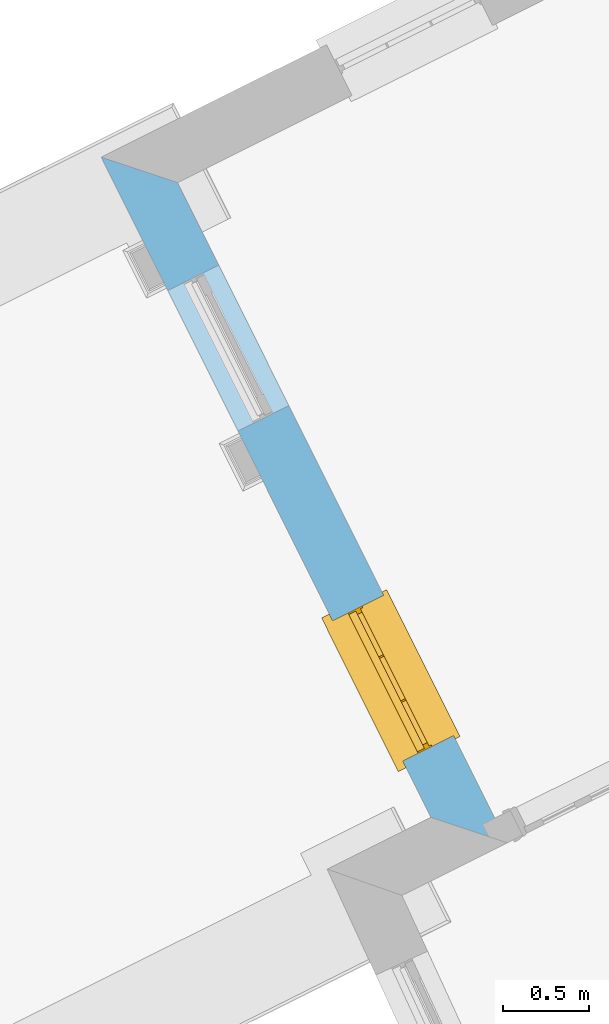
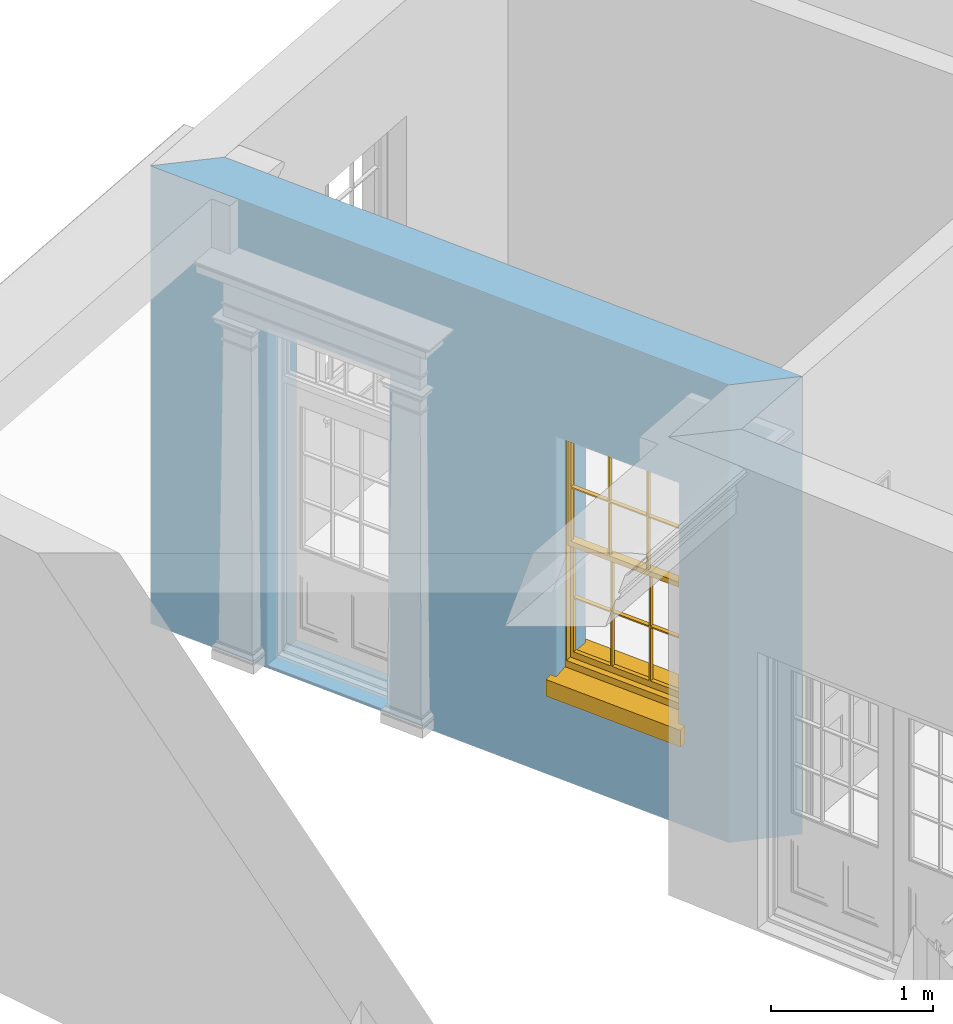
# One storey, part 8 of 10: 1 window, 2 openings, plus 1 element that does not belong to this part.
"""IFC2X3 building model written with IfcOpenShell, lengths in metres."""

from ifc_helpers import new_model, si_unit, frame, origin, place, context, subcontext, project, spatial, polyline, outline, extrude, faceted_brep, material, layer, layer_set, layer_usage, element, fill, save


model = new_model("IFC2X3")

# Units and contexts
model_context = context("Model", 3, world=origin())
body_context = subcontext(model_context, "Body", "Model", "MODEL_VIEW")
ifc_project = project(units=[si_unit("PLANEANGLEUNIT", "RADIAN"), si_unit("MASSUNIT", "GRAM", prefix="KILO"), si_unit("FORCEUNIT", "NEWTON", prefix="KILO"), si_unit("LENGTHUNIT", "METRE")], contexts=[model_context])

# Site, building, storey
site_placement = place(None, origin())
site = spatial("IfcSite", under=ifc_project, at=site_placement, CompositionType="ELEMENT")
building_placement = place(None, origin())
building = spatial("IfcBuilding", under=site, at=building_placement, Name="Building plot-8", CompositionType="ELEMENT")
storey_placement = place(None, origin())
storey = spatial("IfcBuildingStorey", under=building, at=storey_placement, Name="Floor 0", CompositionType="ELEMENT", Elevation=0.0)

# Wall, openings, window
ifc_material = material(Name="Masonry")
ifc_layer = layer(ifc_material, 0.33, ventilated=False)
ifc_layer_set = layer_set([ifc_layer], Name="My Wall")
ifc_layer_usage = layer_usage(ifc_layer_set, "AXIS2", "NEGATIVE", 0.08)
wall_placement = place(storey_placement, origin())
wall = element("IfcWallStandardCase", 1, at=wall_placement, inside=storey, material=ifc_layer_usage, Name="exterior", context=body_context, shape_type="SweptSolid", body=[
    extrude(outline(polyline([(22.6049906081901, 17.1432536383612), (22.162338538902, 17.2911020254168), (24.0721987779004, 13.4655957286817), (24.5148508471885, 13.3177473416261), (22.6049906081901, 17.1432536383612)])), origin(), (0.0, 0.0, 1.0), 3.45),
])
opening_1_placement = place(storey_placement, frame((0.0, 0.0, 0.02)))
element("IfcOpeningElement", 2, at=opening_1_placement, cuts=wall, Name="Opening", ObjectType="Opening", context=body_context, shape_type="SweptSolid", body=[
    extrude(outline(polyline([(22.5482357882612, 16.518138471764), (22.9547075319454, 15.7039636001386), (23.2499577601173, 15.8513654412549), (22.843486016433, 16.6655403128803), (22.5482357882612, 16.518138471764)])), origin(), (0.0, 0.0, 1.0), 2.545),
])
opening_2_placement = place(storey_placement, frame((0.0, 0.0, 0.75)))
opening_2 = element("IfcOpeningElement", 3, at=opening_2_placement, cuts=wall, Name="Opening", ObjectType="Opening", context=body_context, shape_type="SweptSolid", body=[
    extrude(outline(polyline([(23.5031659077604, 14.6053853233965), (23.9096376514446, 13.791210451771), (24.2048878796165, 13.9386122928873), (23.7984161359322, 14.7527871645127), (23.5031659077604, 14.6053853233965)])), origin(), (0.0, 0.0, 1.0), 1.82),
])
window_placement = place(storey_placement, frame((23.7268403230421, 14.7170533848482, 0.75), z_axis=(0.0, 0.0, 1.0), x_axis=(0.406471743684261, -0.814174871625426, 0.0)))
window = element("IfcWindow", 4, at=window_placement, inside=storey, Name="circulation outside window", OverallHeight=1.82, OverallWidth=0.91, context=body_context, shape_type="Brep", held_by="IfcProductRepresentation", body=[
    faceted_brep([(0.033125, -0.105, 0.975209), (0.01, -0.105, 0.975209), (0.033125, -0.105, 1.376042), (0.876875, -0.105, 0.975209), (0.876875, -0.105, 1.376042), (0.9, -0.105, 0.975209), (0.876875, -0.105, 1.386042), (0.876875, -0.105, 1.786875), (0.9, -0.105, 1.81), (0.033125, -0.105, 1.786875), (0.033125, -0.105, 1.386042), (0.01, -0.105, 1.81), (0.876875, -0.135, 1.376042), (0.876875, -0.135, 0.975209), (0.9, -0.135, 0.937083), (0.033125, -0.135, 1.786875), (0.01, -0.135, 1.81), (0.033125, -0.135, 1.386042), (0.01, -0.135, 0.937083), (0.033125, -0.135, 0.975209), (0.033125, -0.135, 1.376042), (0.876875, -0.135, 1.786875), (0.876875, -0.135, 1.386042), (0.9, -0.135, 1.81), (0.033125, -0.105, 0.937083), (0.01, -0.105, 0.937083), (0.033125, -0.105, 0.53625), (0.876875, -0.105, 0.937083), (0.876875, -0.105, 0.53625), (0.9, -0.105, 0.937083), (0.876875, -0.105, 0.52625), (0.876875, -0.105, 0.125417), (0.9, -0.105, 0.077167), (0.033125, -0.105, 0.125417), (0.033125, -0.105, 0.52625), (0.01, -0.105, 0.077167), (-0.0425, -0.25, 0.01), (-0.0425, -0.3, 0.001667), (0.0, -0.25, 0.01), (0.9525, -0.25, 0.01), (0.91, -0.25, 0.01), (0.9525, -0.3, 0.001667), (-0.02, 0.08, 0.077167), (0.0, 0.08, 0.077167), (-0.02, 0.11, 0.077167), (0.0, -0.06, 0.077167), (0.01, -0.06, 0.077167), (0.91, -0.06, 0.077167), (0.91, 0.08, 0.077167), (0.9, -0.06, 0.077167), (0.93, 0.08, 0.077167), (0.93, 0.11, 0.077167), (0.01, -0.075, 0.975209), (0.9, -0.075, 0.975209), (0.876875, -0.075, 0.125417), (0.876875, -0.075, 0.52625), (0.9, -0.075, 0.077167), (0.876875, -0.075, 0.53625), (0.876875, -0.075, 0.937083), (0.033125, -0.075, 0.125417), (0.01, -0.075, 0.077167), (0.033125, -0.075, 0.52625), (0.033125, -0.075, 0.937083), (0.033125, -0.075, 0.53625), (-0.02, 0.08, 0.052167), (-0.02, 0.11, 0.052167), (0.93, 0.11, 0.052167), (0.93, 0.08, 0.052167), (0.91, 0.08, 0.052167), (0.0, 0.08, 0.052167), (0.91, -0.15, 0.026667), (0.0, -0.15, 0.026667), (-0.0425, -0.3, -0.123333), (0.9525, -0.3, -0.123333), (-0.0425, -0.25, -0.123333), (0.9525, -0.25, -0.123333), (0.01, -0.06, 1.81), (0.9, -0.06, 1.81), (0.0, -0.06, 1.82), (0.91, -0.06, 1.82), (0.01, -0.15, 0.077167), (0.9, -0.15, 0.077167), (0.592292, -0.105, 0.125417), (0.592292, -0.075, 0.125417), (0.317708, -0.075, 0.125417), (0.317708, -0.105, 0.125417), (0.592292, -0.105, 0.53625), (0.317708, -0.105, 0.53625), (0.317708, -0.105, 0.52625), (0.592292, -0.105, 0.52625), (0.592292, -0.075, 0.53625), (0.317708, -0.075, 0.53625), (0.592292, -0.135, 1.386042), (0.592292, -0.105, 1.386042), (0.317708, -0.105, 1.386042), (0.317708, -0.135, 1.386042), (0.317708, -0.135, 1.376042), (0.592292, -0.135, 1.376042), (0.317708, -0.105, 1.376042), (0.592292, -0.105, 1.376042), (0.602292, -0.135, 1.376042), (0.592292, -0.135, 0.975209), (0.602292, -0.135, 0.975209), (0.602292, -0.105, 0.975209), (0.592292, -0.105, 0.975209), (0.602292, -0.105, 1.376042), (0.602292, -0.075, 0.53625), (0.602292, -0.105, 0.53625), (0.317708, -0.075, 0.52625), (0.307708, -0.075, 0.125417), (0.307708, -0.075, 0.52625), (0.602292, -0.075, 0.52625), (0.602292, -0.075, 0.125417), (0.592292, -0.075, 0.52625), (0.307708, -0.075, 0.53625), (0.317708, -0.075, 0.937083), (0.307708, -0.075, 0.937083), (0.602292, -0.075, 0.937083), (0.592292, -0.075, 0.937083), (0.307708, -0.105, 0.52625), (0.307708, -0.105, 0.125417), (0.307708, -0.105, 0.53625), (0.307708, -0.105, 0.937083), (0.592292, -0.105, 0.937083), (0.317708, -0.105, 0.937083), (0.602292, -0.105, 0.937083), (0.602292, -0.105, 0.52625), (0.602292, -0.105, 0.125417), (0.307708, -0.135, 1.386042), (0.307708, -0.135, 1.376042), (0.307708, -0.135, 0.975209), (0.317708, -0.135, 0.975209), (0.317708, -0.135, 1.786875), (0.307708, -0.135, 1.786875), (0.602292, -0.135, 1.786875), (0.592292, -0.135, 1.786875), (0.602292, -0.135, 1.386042), (0.602292, -0.105, 1.386042), (0.307708, -0.105, 1.386042), (0.307708, -0.105, 1.786875), (0.317708, -0.105, 1.786875), (0.592292, -0.105, 1.786875), (0.602292, -0.105, 1.786875), (0.307708, -0.105, 1.376042), (0.317708, -0.105, 0.975209), (0.307708, -0.105, 0.975209), (0.91, -0.15, 1.82), (0.9, -0.15, 1.81), (0.01, -0.15, 1.81), (0.0, -0.15, 1.82), (0.91, -0.25, 0.0), (0.0, -0.25, 0.0), (0.91, 0.08, 0.0), (0.0, 0.08, 0.0)], [[[0, 1, 2]], [[3, 4, 5]], [[6, 7, 8]], [[9, 10, 11]], [[12, 13, 14]], [[15, 16, 17]], [[18, 19, 20]], [[21, 22, 23]], [[24, 25, 26]], [[27, 28, 29]], [[30, 31, 32]], [[33, 34, 35]], [[14, 27, 29]], [[25, 24, 18]], [[36, 37, 38]], [[39, 40, 41]], [[42, 43, 44]], [[45, 46, 43]], [[47, 48, 49]], [[50, 51, 48]], [[1, 0, 52]], [[5, 53, 3]], [[54, 55, 56]], [[57, 58, 53]], [[59, 60, 61]], [[62, 63, 52]], [[48, 43, 46, 49]], [[51, 44, 43, 48]], [[64, 42, 44, 65]], [[65, 44, 51, 66]], [[66, 51, 50, 67]], [[65, 66, 68, 69]], [[60, 56, 49, 46]], [[70, 71, 38, 40]], [[37, 41, 40, 38]], [[37, 72, 73, 41]], [[74, 75, 73, 72]], [[8, 11, 76, 77]], [[76, 78, 79, 77]], [[32, 35, 80, 81]], [[81, 80, 71, 70]], [[82, 83, 84, 85]], [[86, 87, 88, 89]], [[86, 90, 91, 87]], [[92, 93, 94, 95]], [[92, 95, 96, 97]], [[96, 98, 99, 97]], [[100, 97, 101, 102]], [[103, 104, 99, 105]], [[97, 99, 104, 101]], [[102, 103, 105, 100]], [[28, 57, 106, 107]], [[108, 84, 109, 110]], [[111, 112, 83, 113]], [[114, 110, 61, 63]], [[90, 113, 108, 91]], [[115, 91, 114, 116]], [[117, 106, 90, 118]], [[111, 106, 57, 55]], [[119, 110, 109, 120]], [[34, 61, 110, 119]], [[89, 113, 83, 82]], [[88, 108, 113, 89]], [[85, 84, 108, 88]], [[121, 114, 63, 26]], [[122, 116, 114, 121]], [[123, 118, 90, 86]], [[87, 91, 115, 124]], [[107, 106, 117, 125]], [[126, 111, 55, 30]], [[127, 112, 111, 126]], [[126, 30, 28, 107]], [[88, 119, 120, 85]], [[126, 89, 82, 127]], [[125, 123, 86, 107]], [[121, 26, 34, 119]], [[124, 122, 121, 87]], [[128, 17, 20, 129]], [[96, 129, 130, 131]], [[132, 133, 128, 95]], [[134, 135, 92, 136]], [[100, 12, 22, 136]], [[137, 6, 4, 105]], [[94, 138, 139, 140]], [[137, 93, 141, 142]], [[99, 98, 94, 93]], [[143, 2, 10, 138]], [[144, 145, 143, 98]], [[129, 143, 145, 130]], [[20, 2, 143, 129]], [[131, 144, 98, 96]], [[128, 138, 10, 17]], [[133, 139, 138, 128]], [[135, 141, 93, 92]], [[95, 94, 140, 132]], [[22, 6, 137, 136]], [[136, 137, 142, 134]], [[100, 105, 4, 12]], [[107, 86, 89, 126]], [[106, 111, 113, 90]], [[91, 108, 110, 114]], [[87, 121, 119, 88]], [[97, 100, 136, 92]], [[129, 96, 95, 128]], [[98, 143, 138, 94]], [[105, 99, 93, 137]], [[131, 101, 104, 144]], [[124, 115, 118, 123]], [[132, 140, 141, 135]], [[120, 109, 59, 33]], [[15, 9, 139, 133]], [[134, 142, 7, 21]], [[31, 54, 112, 127]], [[36, 74, 72, 37]], [[39, 41, 73, 75]], [[18, 14, 101, 131]], [[23, 16, 132, 135]], [[83, 56, 60, 84]], [[52, 53, 118, 115]], [[53, 52, 144, 104]], [[11, 8, 141, 140]], [[14, 18, 124, 123]], [[2, 1, 11, 10]], [[8, 5, 4, 6]], [[57, 53, 56, 55]], [[60, 52, 63, 61]], [[26, 25, 35, 34]], [[32, 29, 28, 30]], [[14, 23, 22, 12]], [[18, 20, 17, 16]], [[19, 0, 2, 20]], [[17, 10, 9, 15]], [[12, 4, 3, 13]], [[21, 7, 6, 22]], [[27, 58, 57, 28]], [[30, 55, 54, 31]], [[33, 59, 61, 34]], [[26, 63, 62, 24]], [[5, 8, 77, 53]], [[76, 11, 1, 52]], [[46, 45, 78, 76]], [[49, 77, 79, 47]], [[70, 146, 147, 81]], [[71, 80, 148, 149]], [[19, 130, 145, 0]], [[102, 13, 3, 103]], [[116, 122, 24, 62]], [[29, 32, 81, 14]], [[80, 35, 25, 18]], [[60, 46, 76, 52]], [[77, 49, 56, 53]], [[23, 14, 81, 147]], [[16, 148, 80, 18]], [[35, 85, 120]], [[120, 33, 35]], [[127, 82, 32]], [[32, 31, 127]], [[32, 82, 85, 35]], [[102, 101, 14]], [[14, 13, 102]], [[18, 131, 130]], [[130, 19, 18]], [[134, 21, 23]], [[23, 135, 134]], [[16, 15, 133]], [[133, 132, 16]], [[11, 140, 139]], [[139, 9, 11]], [[142, 141, 8]], [[8, 7, 142]], [[23, 147, 148, 16]], [[146, 149, 148, 147]], [[52, 115, 116]], [[116, 62, 52]], [[118, 53, 117]], [[58, 117, 53]], [[27, 125, 117, 58]], [[56, 83, 112]], [[112, 54, 56]], [[109, 84, 60]], [[60, 59, 109]], [[125, 27, 14]], [[14, 123, 125]], [[122, 124, 18]], [[18, 24, 122]], [[145, 144, 52]], [[52, 0, 145]], [[103, 3, 53]], [[53, 104, 103]], [[79, 78, 149, 146]], [[78, 45, 71, 149]], [[146, 70, 47, 79]], [[150, 75, 74, 151]], [[68, 66, 67]], [[48, 68, 67, 50]], [[69, 64, 65]], [[42, 64, 69, 43]], [[69, 68, 152, 153]], [[70, 68, 48, 47]], [[150, 152, 68, 70]], [[43, 69, 71, 45]], [[69, 153, 151, 71]], [[152, 150, 151, 153]], [[38, 151, 74, 36]], [[71, 151, 38]], [[39, 75, 150, 40]], [[40, 150, 70]]]),
])
fill(opening_2, window)

save(model, "model.ifc")
